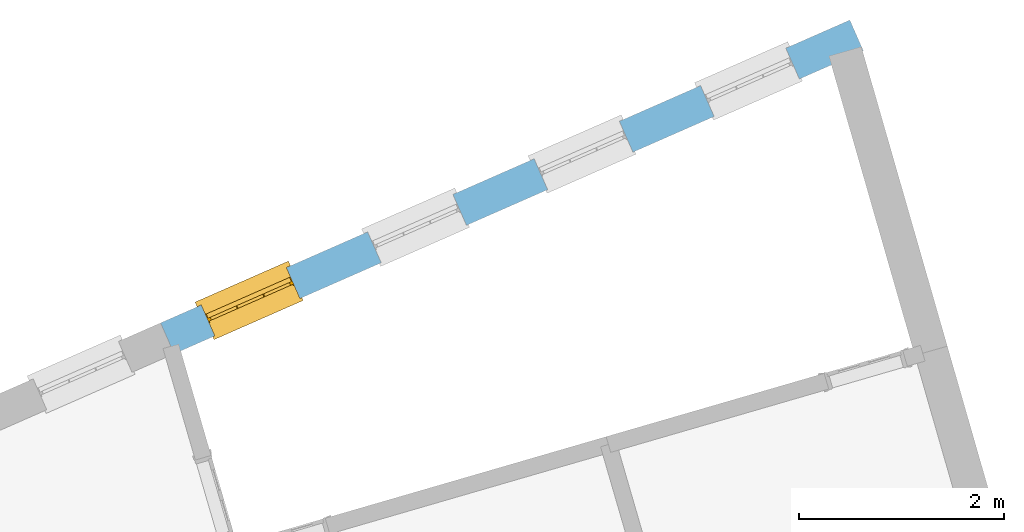
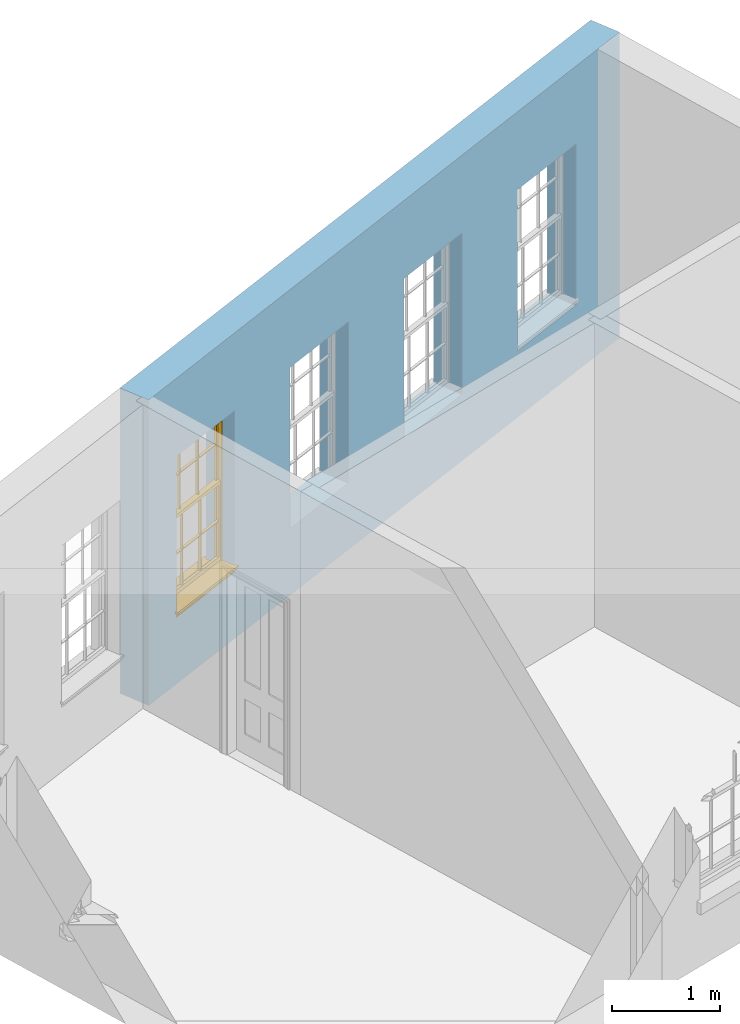
# One storey, part 9 of 11: 1 window, 4 openings, plus 1 element that does not belong to this part.
"""IFC2X3 building model written with IfcOpenShell, lengths in metres."""

from ifc_helpers import new_model, si_unit, frame, origin, place, context, subcontext, project, spatial, polyline, outline, extrude, faceted_brep, material, layer, layer_set, layer_usage, element, fill, save


model = new_model("IFC2X3")

# Units and contexts
model_context = context("Model", 3, world=origin())
body_context = subcontext(model_context, "Body", "Model", "MODEL_VIEW")
ifc_project = project(units=[si_unit("PLANEANGLEUNIT", "RADIAN"), si_unit("MASSUNIT", "GRAM", prefix="KILO"), si_unit("FORCEUNIT", "NEWTON", prefix="KILO"), si_unit("LENGTHUNIT", "METRE")], contexts=[model_context])

# Site, building, storey
site_placement = place(None, origin())
site = spatial("IfcSite", under=ifc_project, at=site_placement, CompositionType="ELEMENT")
building_placement = place(None, origin())
building = spatial("IfcBuilding", under=site, at=building_placement, Name="Building plot-15", CompositionType="ELEMENT")
storey_placement = place(None, frame((0.0, 0.0, 7.6)))
storey = spatial("IfcBuildingStorey", under=building, at=storey_placement, Name="Floor 1", CompositionType="ELEMENT", Elevation=7.6)

# Wall, openings, window
ifc_material = material(Name="Masonry")
ifc_layer = layer(ifc_material, 0.33, ventilated=False)
ifc_layer_set = layer_set([ifc_layer], Name="My Wall")
ifc_layer_usage = layer_usage(ifc_layer_set, "AXIS2", "NEGATIVE", 0.08)
wall_placement = place(storey_placement, origin())
wall = element("IfcWallStandardCase", 1, at=wall_placement, inside=storey, material=ifc_layer_usage, Name="exterior", context=body_context, shape_type="SweptSolid", body=[
    extrude(outline(polyline([(95.6723187451732, 60.4106615143609), (95.5395561949644, 60.7127775603797), (88.804220166514, 57.7529864488727), (88.9369827167228, 57.4508704028539), (95.6723187451732, 60.4106615143609)])), origin(), (0.0, 0.0, 1.0), 3.45),
])
opening_1_placement = place(storey_placement, frame((0.0, 0.0, 0.75)))
element("IfcOpeningElement", 2, at=opening_1_placement, cuts=wall, Name="Opening", ObjectType="Opening", context=body_context, shape_type="SweptSolid", body=[
    extrude(outline(polyline([(94.9139268152625, 60.4378495880681), (94.0808189307863, 60.0717467980984), (94.2135814809951, 59.7696307520796), (95.0466893654713, 60.1357335420493), (94.9139268152625, 60.4378495880681)])), origin(), (0.0, 0.0, 1.0), 1.82),
])
opening_2_placement = place(storey_placement, frame((0.0, 0.0, 0.75)))
element("IfcOpeningElement", 3, at=opening_2_placement, cuts=wall, Name="Opening", ObjectType="Opening", context=body_context, shape_type="SweptSolid", body=[
    extrude(outline(polyline([(93.2873117562595, 59.7230462325794), (92.4542038717833, 59.3569434426097), (92.5869664219921, 59.0548273965908), (93.4200743064683, 59.4209301865605), (93.2873117562595, 59.7230462325794)])), origin(), (0.0, 0.0, 1.0), 1.82),
])
opening_3_placement = place(storey_placement, frame((0.0, 0.0, 0.75)))
element("IfcOpeningElement", 4, at=opening_3_placement, cuts=wall, Name="Opening", ObjectType="Opening", context=body_context, shape_type="SweptSolid", body=[
    extrude(outline(polyline([(91.6606966972566, 59.0082428770907), (90.8275888127803, 58.642140087121), (90.9603513629891, 58.3400240411021), (91.7934592474653, 58.7061268310718), (91.6606966972566, 59.0082428770907)])), origin(), (0.0, 0.0, 1.0), 1.82),
])
opening_4_placement = place(storey_placement, frame((0.0, 0.0, 0.75)))
opening_4 = element("IfcOpeningElement", 5, at=opening_4_placement, cuts=wall, Name="Opening", ObjectType="Opening", context=body_context, shape_type="SweptSolid", body=[
    extrude(outline(polyline([(90.0340816382536, 58.2934395216019), (89.2009737537774, 57.9273367316322), (89.3337363039862, 57.6252206856134), (90.1668441884623, 57.9913234755831), (90.0340816382536, 58.2934395216019)])), origin(), (0.0, 0.0, 1.0), 1.82),
])
window_placement = place(storey_placement, frame((90.1346593278057, 58.0645637291634, 0.75), z_axis=(0.0, 0.0, 1.0), x_axis=(-0.833107884476192, -0.366102789969688, 0.0)))
window = element("IfcWindow", 6, at=window_placement, inside=storey, Name="circulation outside window", OverallHeight=1.82, OverallWidth=0.91, context=body_context, shape_type="Brep", held_by="IfcProductRepresentation", body=[
    faceted_brep([(0.033125, -0.105, 0.975209), (0.01, -0.105, 0.975209), (0.033125, -0.105, 1.376042), (0.876875, -0.105, 0.975209), (0.876875, -0.105, 1.376042), (0.9, -0.105, 0.975209), (0.876875, -0.105, 1.386042), (0.876875, -0.105, 1.786875), (0.9, -0.105, 1.81), (0.033125, -0.105, 1.786875), (0.033125, -0.105, 1.386042), (0.01, -0.105, 1.81), (0.876875, -0.135, 1.376042), (0.876875, -0.135, 0.975209), (0.9, -0.135, 0.937083), (0.033125, -0.135, 1.786875), (0.01, -0.135, 1.81), (0.033125, -0.135, 1.386042), (0.01, -0.135, 0.937083), (0.033125, -0.135, 0.975209), (0.033125, -0.135, 1.376042), (0.876875, -0.135, 1.786875), (0.876875, -0.135, 1.386042), (0.9, -0.135, 1.81), (0.033125, -0.105, 0.937083), (0.01, -0.105, 0.937083), (0.033125, -0.105, 0.53625), (0.876875, -0.105, 0.937083), (0.876875, -0.105, 0.53625), (0.9, -0.105, 0.937083), (0.876875, -0.105, 0.52625), (0.876875, -0.105, 0.125417), (0.9, -0.105, 0.077167), (0.033125, -0.105, 0.125417), (0.033125, -0.105, 0.52625), (0.01, -0.105, 0.077167), (-0.0425, -0.25, 0.01), (-0.0425, -0.3, 0.001667), (0.0, -0.25, 0.01), (0.9525, -0.25, 0.01), (0.91, -0.25, 0.01), (0.9525, -0.3, 0.001667), (-0.02, 0.08, 0.077167), (0.0, 0.08, 0.077167), (-0.02, 0.11, 0.077167), (0.0, -0.06, 0.077167), (0.01, -0.06, 0.077167), (0.91, -0.06, 0.077167), (0.91, 0.08, 0.077167), (0.9, -0.06, 0.077167), (0.93, 0.08, 0.077167), (0.93, 0.11, 0.077167), (0.01, -0.075, 0.975209), (0.9, -0.075, 0.975209), (0.876875, -0.075, 0.125417), (0.876875, -0.075, 0.52625), (0.9, -0.075, 0.077167), (0.876875, -0.075, 0.53625), (0.876875, -0.075, 0.937083), (0.033125, -0.075, 0.125417), (0.01, -0.075, 0.077167), (0.033125, -0.075, 0.52625), (0.033125, -0.075, 0.937083), (0.033125, -0.075, 0.53625), (-0.02, 0.08, 0.052167), (-0.02, 0.11, 0.052167), (0.93, 0.11, 0.052167), (0.93, 0.08, 0.052167), (0.91, 0.08, 0.052167), (0.0, 0.08, 0.052167), (0.91, -0.15, 0.026667), (0.0, -0.15, 0.026667), (-0.0425, -0.3, -0.123333), (0.9525, -0.3, -0.123333), (-0.0425, -0.25, -0.123333), (0.9525, -0.25, -0.123333), (0.01, -0.06, 1.81), (0.9, -0.06, 1.81), (0.0, -0.06, 1.82), (0.91, -0.06, 1.82), (0.01, -0.15, 0.077167), (0.9, -0.15, 0.077167), (0.592292, -0.105, 0.125417), (0.592292, -0.075, 0.125417), (0.317708, -0.075, 0.125417), (0.317708, -0.105, 0.125417), (0.592292, -0.105, 0.53625), (0.317708, -0.105, 0.53625), (0.317708, -0.105, 0.52625), (0.592292, -0.105, 0.52625), (0.592292, -0.075, 0.53625), (0.317708, -0.075, 0.53625), (0.592292, -0.135, 1.386042), (0.592292, -0.105, 1.386042), (0.317708, -0.105, 1.386042), (0.317708, -0.135, 1.386042), (0.317708, -0.135, 1.376042), (0.592292, -0.135, 1.376042), (0.317708, -0.105, 1.376042), (0.592292, -0.105, 1.376042), (0.602292, -0.135, 1.376042), (0.592292, -0.135, 0.975209), (0.602292, -0.135, 0.975209), (0.602292, -0.105, 0.975209), (0.592292, -0.105, 0.975209), (0.602292, -0.105, 1.376042), (0.602292, -0.075, 0.53625), (0.602292, -0.105, 0.53625), (0.317708, -0.075, 0.52625), (0.307708, -0.075, 0.125417), (0.307708, -0.075, 0.52625), (0.602292, -0.075, 0.52625), (0.602292, -0.075, 0.125417), (0.592292, -0.075, 0.52625), (0.307708, -0.075, 0.53625), (0.317708, -0.075, 0.937083), (0.307708, -0.075, 0.937083), (0.602292, -0.075, 0.937083), (0.592292, -0.075, 0.937083), (0.307708, -0.105, 0.52625), (0.307708, -0.105, 0.125417), (0.307708, -0.105, 0.53625), (0.307708, -0.105, 0.937083), (0.592292, -0.105, 0.937083), (0.317708, -0.105, 0.937083), (0.602292, -0.105, 0.937083), (0.602292, -0.105, 0.52625), (0.602292, -0.105, 0.125417), (0.307708, -0.135, 1.386042), (0.307708, -0.135, 1.376042), (0.307708, -0.135, 0.975209), (0.317708, -0.135, 0.975209), (0.317708, -0.135, 1.786875), (0.307708, -0.135, 1.786875), (0.602292, -0.135, 1.786875), (0.592292, -0.135, 1.786875), (0.602292, -0.135, 1.386042), (0.602292, -0.105, 1.386042), (0.307708, -0.105, 1.386042), (0.307708, -0.105, 1.786875), (0.317708, -0.105, 1.786875), (0.592292, -0.105, 1.786875), (0.602292, -0.105, 1.786875), (0.307708, -0.105, 1.376042), (0.317708, -0.105, 0.975209), (0.307708, -0.105, 0.975209), (0.91, -0.15, 1.82), (0.9, -0.15, 1.81), (0.01, -0.15, 1.81), (0.0, -0.15, 1.82), (0.91, -0.25, 0.0), (0.0, -0.25, 0.0), (0.91, 0.08, 0.0), (0.0, 0.08, 0.0)], [[[0, 1, 2]], [[3, 4, 5]], [[6, 7, 8]], [[9, 10, 11]], [[12, 13, 14]], [[15, 16, 17]], [[18, 19, 20]], [[21, 22, 23]], [[24, 25, 26]], [[27, 28, 29]], [[30, 31, 32]], [[33, 34, 35]], [[14, 27, 29]], [[25, 24, 18]], [[36, 37, 38]], [[39, 40, 41]], [[42, 43, 44]], [[45, 46, 43]], [[47, 48, 49]], [[50, 51, 48]], [[1, 0, 52]], [[5, 53, 3]], [[54, 55, 56]], [[57, 58, 53]], [[59, 60, 61]], [[62, 63, 52]], [[48, 43, 46, 49]], [[51, 44, 43, 48]], [[64, 42, 44, 65]], [[65, 44, 51, 66]], [[66, 51, 50, 67]], [[65, 66, 68, 69]], [[60, 56, 49, 46]], [[70, 71, 38, 40]], [[37, 41, 40, 38]], [[37, 72, 73, 41]], [[74, 75, 73, 72]], [[8, 11, 76, 77]], [[76, 78, 79, 77]], [[32, 35, 80, 81]], [[81, 80, 71, 70]], [[82, 83, 84, 85]], [[86, 87, 88, 89]], [[86, 90, 91, 87]], [[92, 93, 94, 95]], [[92, 95, 96, 97]], [[96, 98, 99, 97]], [[100, 97, 101, 102]], [[103, 104, 99, 105]], [[97, 99, 104, 101]], [[102, 103, 105, 100]], [[28, 57, 106, 107]], [[108, 84, 109, 110]], [[111, 112, 83, 113]], [[114, 110, 61, 63]], [[90, 113, 108, 91]], [[115, 91, 114, 116]], [[117, 106, 90, 118]], [[111, 106, 57, 55]], [[119, 110, 109, 120]], [[34, 61, 110, 119]], [[89, 113, 83, 82]], [[88, 108, 113, 89]], [[85, 84, 108, 88]], [[121, 114, 63, 26]], [[122, 116, 114, 121]], [[123, 118, 90, 86]], [[87, 91, 115, 124]], [[107, 106, 117, 125]], [[126, 111, 55, 30]], [[127, 112, 111, 126]], [[126, 30, 28, 107]], [[88, 119, 120, 85]], [[126, 89, 82, 127]], [[125, 123, 86, 107]], [[121, 26, 34, 119]], [[124, 122, 121, 87]], [[128, 17, 20, 129]], [[96, 129, 130, 131]], [[132, 133, 128, 95]], [[134, 135, 92, 136]], [[100, 12, 22, 136]], [[137, 6, 4, 105]], [[94, 138, 139, 140]], [[137, 93, 141, 142]], [[99, 98, 94, 93]], [[143, 2, 10, 138]], [[144, 145, 143, 98]], [[129, 143, 145, 130]], [[20, 2, 143, 129]], [[131, 144, 98, 96]], [[128, 138, 10, 17]], [[133, 139, 138, 128]], [[135, 141, 93, 92]], [[95, 94, 140, 132]], [[22, 6, 137, 136]], [[136, 137, 142, 134]], [[100, 105, 4, 12]], [[107, 86, 89, 126]], [[106, 111, 113, 90]], [[91, 108, 110, 114]], [[87, 121, 119, 88]], [[97, 100, 136, 92]], [[129, 96, 95, 128]], [[98, 143, 138, 94]], [[105, 99, 93, 137]], [[131, 101, 104, 144]], [[124, 115, 118, 123]], [[132, 140, 141, 135]], [[120, 109, 59, 33]], [[15, 9, 139, 133]], [[134, 142, 7, 21]], [[31, 54, 112, 127]], [[36, 74, 72, 37]], [[39, 41, 73, 75]], [[18, 14, 101, 131]], [[23, 16, 132, 135]], [[83, 56, 60, 84]], [[52, 53, 118, 115]], [[53, 52, 144, 104]], [[11, 8, 141, 140]], [[14, 18, 124, 123]], [[2, 1, 11, 10]], [[8, 5, 4, 6]], [[57, 53, 56, 55]], [[60, 52, 63, 61]], [[26, 25, 35, 34]], [[32, 29, 28, 30]], [[14, 23, 22, 12]], [[18, 20, 17, 16]], [[19, 0, 2, 20]], [[17, 10, 9, 15]], [[12, 4, 3, 13]], [[21, 7, 6, 22]], [[27, 58, 57, 28]], [[30, 55, 54, 31]], [[33, 59, 61, 34]], [[26, 63, 62, 24]], [[5, 8, 77, 53]], [[76, 11, 1, 52]], [[46, 45, 78, 76]], [[49, 77, 79, 47]], [[70, 146, 147, 81]], [[71, 80, 148, 149]], [[19, 130, 145, 0]], [[102, 13, 3, 103]], [[116, 122, 24, 62]], [[29, 32, 81, 14]], [[80, 35, 25, 18]], [[60, 46, 76, 52]], [[77, 49, 56, 53]], [[23, 14, 81, 147]], [[16, 148, 80, 18]], [[35, 85, 120]], [[120, 33, 35]], [[127, 82, 32]], [[32, 31, 127]], [[32, 82, 85, 35]], [[102, 101, 14]], [[14, 13, 102]], [[18, 131, 130]], [[130, 19, 18]], [[134, 21, 23]], [[23, 135, 134]], [[16, 15, 133]], [[133, 132, 16]], [[11, 140, 139]], [[139, 9, 11]], [[142, 141, 8]], [[8, 7, 142]], [[23, 147, 148, 16]], [[146, 149, 148, 147]], [[52, 115, 116]], [[116, 62, 52]], [[118, 53, 117]], [[58, 117, 53]], [[27, 125, 117, 58]], [[56, 83, 112]], [[112, 54, 56]], [[109, 84, 60]], [[60, 59, 109]], [[125, 27, 14]], [[14, 123, 125]], [[122, 124, 18]], [[18, 24, 122]], [[145, 144, 52]], [[52, 0, 145]], [[103, 3, 53]], [[53, 104, 103]], [[79, 78, 149, 146]], [[78, 45, 71, 149]], [[146, 70, 47, 79]], [[150, 75, 74, 151]], [[68, 66, 67]], [[48, 68, 67, 50]], [[69, 64, 65]], [[42, 64, 69, 43]], [[69, 68, 152, 153]], [[70, 68, 48, 47]], [[150, 152, 68, 70]], [[43, 69, 71, 45]], [[69, 153, 151, 71]], [[152, 150, 151, 153]], [[38, 151, 74, 36]], [[71, 151, 38]], [[39, 75, 150, 40]], [[40, 150, 70]]]),
])
fill(opening_4, window)

save(model, "model.ifc")
